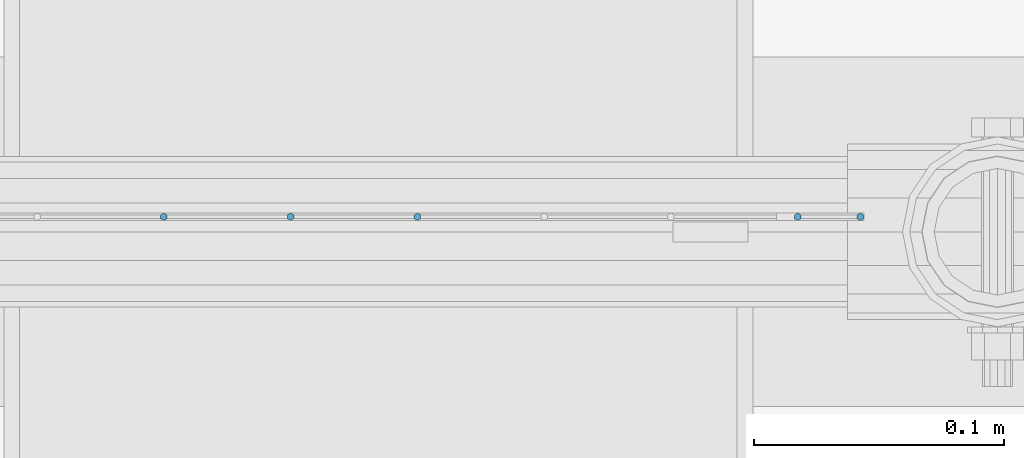
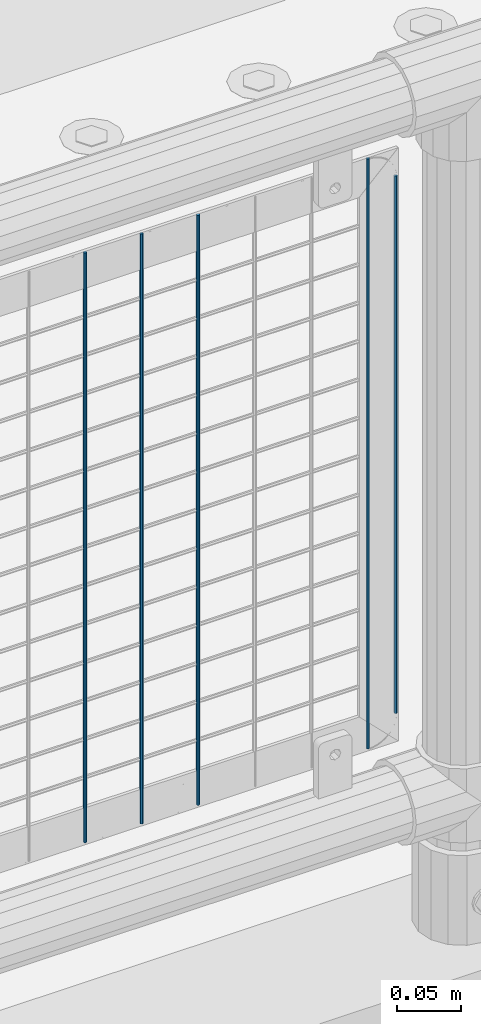
# One storey, part 102 of 270: 5 columns.
"""IFC2X3 building model written with IfcOpenShell, lengths in millimetres."""

import ifcopenshell
import ifcopenshell.guid

model = None  # the IFC model being written
_history = None  # IfcOwnerHistory: only IFC2X3 demands one
_inside = {}  # id of a spatial element -> (the spatial element, [elements in it])
_under = {}  # id of a project, library or spatial element -> (it, [spatial elements below it])
_declared = {}  # id of a project -> (the project, [libraries it declares])
_typed = {}  # id of a type object -> (the type object, [elements of that type])
_made_of = {}  # id of a material, layer set ... -> (it, [elements and type objects made of it])


def new_model(schema):
    """Start an empty IFC model of exactly this schema.

    Asked for "IFC4X3", IfcOpenShell would pick the latest addendum, in which some entities
    have other attributes; the version numbers below select the first issue.
    IFC2X3 requires an IfcOwnerHistory on every rooted entity: one is made here for all.
    """
    global model, _history
    if schema == "IFC4X3":
        model = ifcopenshell.file(schema_version=(4, 3, 0, 0))
    else:
        model = ifcopenshell.file(schema=schema)
    _inside.clear()
    _under.clear()
    _declared.clear()
    _typed.clear()
    _made_of.clear()
    _history = None
    if model.schema == "IFC2X3":
        org = make("IfcOrganization", Name="unknown")
        user = make(
            "IfcPersonAndOrganization",
            ThePerson=make("IfcPerson", FamilyName="unknown"),
            TheOrganization=org,
        )
        app = make(
            "IfcApplication",
            ApplicationDeveloper=org,
            Version="unknown",
            ApplicationFullName="unknown",
            ApplicationIdentifier="unknown",
        )
        _history = make(
            "IfcOwnerHistory",
            OwningUser=user,
            OwningApplication=app,
            ChangeAction="ADDED",
            CreationDate=0,
        )
    return model


def make(cls, **values):
    """One entity of the class cls with the attributes given. An attribute that is None is left unset."""
    return model.create_entity(
        cls, **{name: value for name, value in values.items() if value is not None}
    )


def rooted(cls, **values):
    """An entity with a GlobalId (a new one), such as an element, a storey or a relation."""
    return make(cls, GlobalId=ifcopenshell.guid.new(), OwnerHistory=_history, **values)


def si_unit(unit_type, name, prefix=None):
    """IfcSIUnit, for example si_unit("LENGTHUNIT", "METRE", prefix="MILLI")."""
    return make("IfcSIUnit", UnitType=unit_type, Prefix=prefix, Name=name)


def assignment(units):
    """IfcUnitAssignment: the units of a project."""
    return None if units is None else make("IfcUnitAssignment", Units=units)


def point(xyz):
    """IfcCartesianPoint."""
    return None if xyz is None else make("IfcCartesianPoint", Coordinates=xyz)


def direction(xyz):
    """IfcDirection."""
    return None if xyz is None else make("IfcDirection", DirectionRatios=xyz)


def frame(location, z_axis=None, x_axis=None):
    """IfcAxis2Placement3D, a coordinate frame: its origin and axes. An axis left out is left unset."""
    return make(
        "IfcAxis2Placement3D",
        Location=point(location),
        Axis=direction(z_axis),
        RefDirection=direction(x_axis),
    )


def origin_with_axes():
    """The frame at (0, 0, 0) with the z axis (0, 0, 1) and the x axis (1, 0, 0) written out."""
    return frame((0.0, 0.0, 0.0), z_axis=(0.0, 0.0, 1.0), x_axis=(1.0, 0.0, 0.0))


def place(relative_to, where):
    """IfcLocalPlacement: puts the frame where relative to a parent placement (None: the world)."""
    return make(
        "IfcLocalPlacement", PlacementRelTo=relative_to, RelativePlacement=where
    )


def context(
    kind, dimensions, precision=None, world=None, true_north=None, identifier=None
):
    """IfcGeometricRepresentationContext, for example the 3D "Model" context."""
    return make(
        "IfcGeometricRepresentationContext",
        ContextIdentifier=identifier,
        ContextType=kind,
        CoordinateSpaceDimension=dimensions,
        Precision=precision,
        WorldCoordinateSystem=world,
        TrueNorth=true_north,
    )


def subcontext(parent, identifier, kind, view, scale=None):
    """IfcGeometricRepresentationSubContext, for example "Body" below "Model"."""
    return make(
        "IfcGeometricRepresentationSubContext",
        ContextIdentifier=identifier,
        ContextType=kind,
        ParentContext=parent,
        TargetScale=scale,
        TargetView=view,
    )


def project(units=None, contexts=None):
    """IfcProject with its units and contexts."""
    return rooted(
        "IfcProject",
        Name="project",
        RepresentationContexts=contexts,
        UnitsInContext=assignment(units),
    )


def spatial(cls, under=None, at=None, **own):
    """A site, building, storey or space (cls), placed at a placement, below another one or the project."""
    s = rooted(cls, ObjectPlacement=at, **own)
    if under is not None:
        _under.setdefault(under.id(), (under, []))[1].append(s)
    return s


def faces_of(points, faces, orient=None, outer=None):
    """IfcFace entities. A face is a list of loops; a loop is a list of indices into points, from 0.

    orient and outer hold one flag for each loop. By default every Orientation is true, the
    first loop of a face is its IfcFaceOuterBound and the others are IfcFaceBound.
    """
    made = []
    for i, loops in enumerate(faces):
        bounds = []
        for j, loop in enumerate(loops):
            is_outer = j == 0 if outer is None else outer[i][j]
            bounds.append(
                make(
                    "IfcFaceOuterBound" if is_outer else "IfcFaceBound",
                    Bound=make("IfcPolyLoop", Polygon=[points[k] for k in loop]),
                    Orientation=True if orient is None else orient[i][j],
                )
            )
        made.append(make("IfcFace", Bounds=bounds))
    return made


def faceted_brep(points, faces, orient=None, outer=None, voids=None):
    """IfcFacetedBrep: a solid bounded by flat faces; with voids (closed shells), ...WithVoids."""
    shared = [point(p) for p in points]
    hull = make("IfcClosedShell", CfsFaces=faces_of(shared, faces, orient, outer))
    if voids is None:
        return make("IfcFacetedBrep", Outer=hull)
    return make(
        "IfcFacetedBrepWithVoids",
        Outer=hull,
        Voids=[
            make(cls, CfsFaces=faces_of(shared, fs, o, b)) for cls, fs, o, b in voids
        ],
    )


def shape(context_of_items, identifier, shape_type, items):
    """IfcShapeRepresentation: the items that make up one representation, for example the "Body"."""
    return make(
        "IfcShapeRepresentation",
        ContextOfItems=context_of_items,
        RepresentationIdentifier=identifier,
        RepresentationType=shape_type,
        Items=items,
    )


def material(Name=None, Category=None):
    """IfcMaterial."""
    return make("IfcMaterial", Name=Name, Category=Category)


def made_of(thing, what):
    """Note that an element or type object is made of a material, layer set ...; save() writes the relation."""
    if what is not None:
        _made_of.setdefault(what.id(), (what, []))[1].append(thing)
    return thing


def type_object(cls, material=None, **own):
    """A type object (cls), such as IfcWallType, which elements share."""
    return made_of(rooted(cls, **own), material)


def element(
    cls,
    number,
    at=None,
    inside=None,
    cuts=None,
    type_object=None,
    material=None,
    context=None,
    identifier="Body",
    shape_type=None,
    held_by="IfcProductDefinitionShape",
    body=None,
    shapes=None,
    **own,
):
    """One element of the class cls, such as IfcWall. Its Tag is "e" and its number.

    at: its placement. inside: the storey or other place that contains it. cuts: it is an
    opening in that element (IfcRelVoidsElement). A single representation is given by context,
    identifier, shape_type and body (its items); several are given by shapes. held_by: the class
    of the entity that holds the representations. save() writes the other relations.
    """
    e = rooted(cls, Tag="e%d" % number, ObjectPlacement=at, **own)
    if body is not None:
        shapes = [shape(context, identifier, shape_type, body)]
    if shapes is not None:
        e.Representation = make(held_by, Representations=shapes)
    if inside is not None:
        _inside.setdefault(inside.id(), (inside, []))[1].append(e)
    if cuts is not None:
        rooted(
            "IfcRelVoidsElement", RelatingBuildingElement=cuts, RelatedOpeningElement=e
        )
    if type_object is not None:
        _typed.setdefault(type_object.id(), (type_object, []))[1].append(e)
    return made_of(e, material)


def aggregate(whole, parts):
    """IfcRelAggregates: a whole, such as a stair, and the parts it consists of."""
    return rooted("IfcRelAggregates", RelatingObject=whole, RelatedObjects=parts)


def save(model, path):
    """Write the relations noted so far, then the file.

    IfcRelAggregates (storeys below a building ...), IfcRelContainedInSpatialStructure (elements
    in a storey), IfcRelDefinesByType, IfcRelAssociatesMaterial and IfcRelDeclares: one each for
    every whole, place, type object, material and project.
    """
    for whole, parts in _under.values():
        aggregate(whole, parts)
    for where, things in _inside.values():
        rooted(
            "IfcRelContainedInSpatialStructure",
            RelatedElements=things,
            RelatingStructure=where,
        )
    for kind, things in _typed.values():
        rooted("IfcRelDefinesByType", RelatedObjects=things, RelatingType=kind)
    for what, things in _made_of.values():
        rooted("IfcRelAssociatesMaterial", RelatedObjects=things, RelatingMaterial=what)
    for by, libraries in _declared.values():
        rooted("IfcRelDeclares", RelatingContext=by, RelatedDefinitions=libraries)
    model.write(path)


model = new_model("IFC2X3")

# Units and contexts
model_context = context("Model", 3, precision=1e-05, world=origin_with_axes())
body_context = subcontext(model_context, "Body", "Model", "MODEL_VIEW")
ifc_project = project(units=[si_unit("LENGTHUNIT", "METRE", prefix="MILLI"), si_unit("AREAUNIT", "SQUARE_METRE"), si_unit("VOLUMEUNIT", "CUBIC_METRE"), si_unit("MASSUNIT", "GRAM", prefix="KILO"), si_unit("TIMEUNIT", "SECOND"), si_unit("PLANEANGLEUNIT", "RADIAN"), si_unit("SOLIDANGLEUNIT", "STERADIAN"), si_unit("THERMODYNAMICTEMPERATUREUNIT", "DEGREE_CELSIUS"), si_unit("LUMINOUSINTENSITYUNIT", "LUMEN")], contexts=[model_context])

# Site, building, storey
site_placement = place(None, origin_with_axes())
site = spatial("IfcSite", under=ifc_project, at=site_placement, CompositionType="ELEMENT")
building_placement = place(site_placement, origin_with_axes())
building = spatial("IfcBuilding", under=site, at=building_placement, Name="Standard", CompositionType="ELEMENT")
storey_placement = place(building_placement, origin_with_axes())
storey = spatial("IfcBuildingStorey", under=building, at=storey_placement, Name="Undefined", CompositionType="ELEMENT", Elevation=0.0)

# Columns
ifc_material = material(Name="Misc_Undefined")
column_type = type_object("IfcColumnType", Name="D3", PredefinedType="NOTDEFINED")
for number, where, z_axis, x_axis in (
    (1, (15085.618, -16329.5, 353.02), (-1.0, 0.0, 0.0), (0.0, 0.0, 1.0)),
    (2, (15034.825, -16329.5, 353.02), (-1.0, 0.0, 0.0), (0.0, 0.0, 1.0)),
    (3, (14984.032, -16329.5, 353.02), (-1.0, 0.0, 0.0), (0.0, 0.0, 1.0)),
    (4, (15237.997, -16329.5, 353.02), (-1.0, 0.0, 0.0), (0.0, 0.0, 1.0)),
):
    element("IfcColumn", number, at=place(storey_placement, frame(where, z_axis=z_axis, x_axis=x_axis)), inside=storey, type_object=column_type, material=ifc_material, ObjectType="D3", context=body_context, shape_type="Brep", body=[
        faceted_brep([(0.0, -1.5, 0.0), (0.0, -0.75, -1.29903810567669), (560.0, -0.75, -1.29903810567703), (560.0, -1.5, 0.0), (0.0, 0.75, -1.29903810567669), (560.0, 0.75, -1.29903810567703), (0.0, 1.5, 0.0), (560.0, 1.5, 0.0), (0.0, 0.75, 1.29903810567669), (560.0, 0.75, 1.29903810567703), (0.0, -0.75, 1.29903810567669), (560.0, -0.75, 1.29903810567703)], [[[0, 1, 2, 3]], [[1, 4, 5, 2]], [[4, 6, 7, 5]], [[6, 8, 9, 7]], [[8, 10, 11, 9]], [[10, 0, 3, 11]], [[5, 7, 9, 11, 3, 2]], [[10, 8, 6, 4, 1, 0]]]),
    ])
column_placement = place(storey_placement, frame((15263.0, -16329.5, 378.02), z_axis=(-1.0, 0.0, 0.0), x_axis=(0.0, 0.0, 1.0)))
element("IfcColumn", 5, at=column_placement, inside=storey, type_object=column_type, material=ifc_material, ObjectType="D3", context=body_context, shape_type="Brep", body=[
    faceted_brep([(0.0, -1.5, 0.0), (0.0, -0.75, -1.29903810567669), (510.0, -0.75, -1.29903810567703), (510.0, -1.5, 0.0), (0.0, 0.75, -1.29903810567669), (510.0, 0.75, -1.29903810567703), (0.0, 1.5, 0.0), (510.0, 1.5, 0.0), (0.0, 0.75, 1.29903810567669), (510.0, 0.75, 1.29903810567703), (0.0, -0.75, 1.29903810567669), (510.0, -0.75, 1.29903810567703)], [[[0, 1, 2, 3]], [[1, 4, 5, 2]], [[4, 6, 7, 5]], [[6, 8, 9, 7]], [[8, 10, 11, 9]], [[10, 0, 3, 11]], [[5, 7, 9, 11, 3, 2]], [[10, 8, 6, 4, 1, 0]]]),
])

save(model, "model.ifc")
